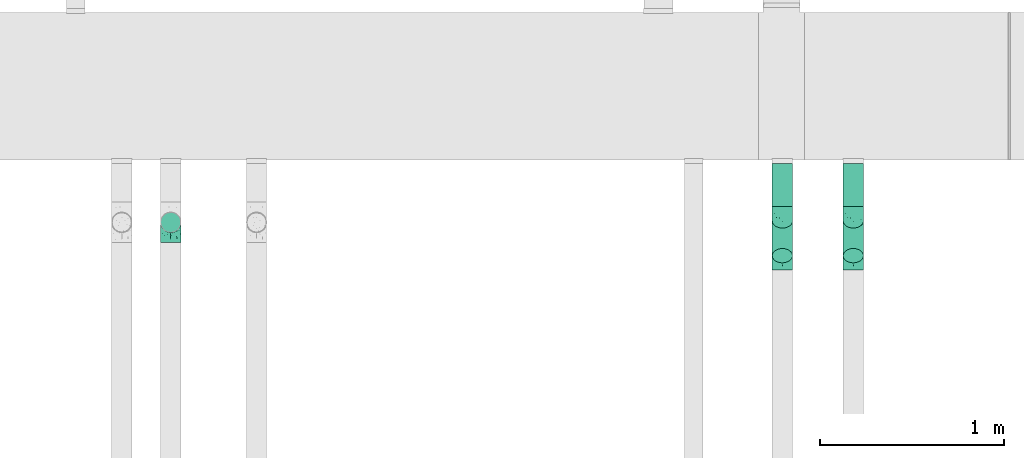
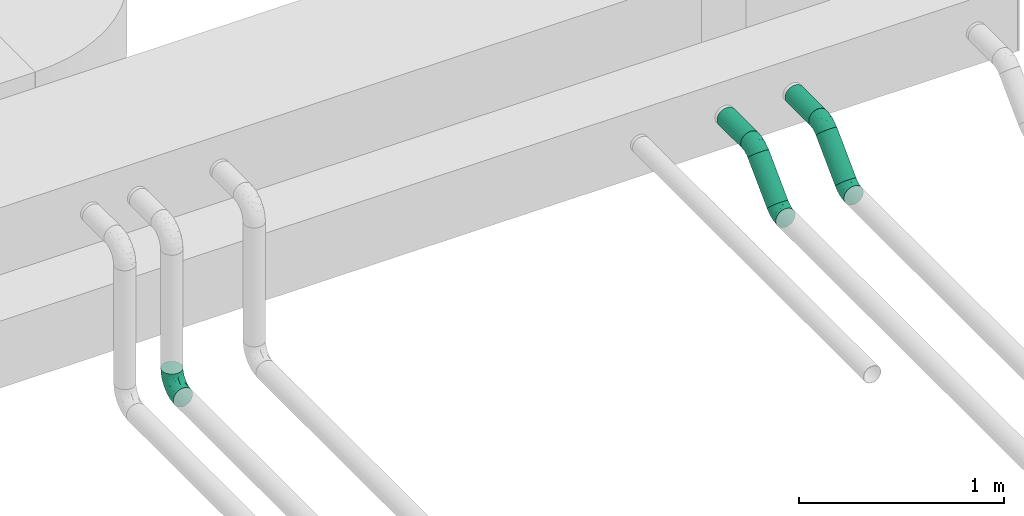
# One storey, part 60 of 91: 5 flow fittings, 4 flow segments.
"""IFC2X3 building model written with IfcOpenShell, lengths in millimetres."""

from ifc_helpers import new_model, entity, si_unit, converted_unit, derived_unit, direction, frame, origin_with_axes, origin_2d_with_axis, place, context, subcontext, project, spatial, hollow_circle, extrude, open_shell, surface_model, source, transform, mapped, material, layer, layer_set, layer_usage, type_object, element, save


model = new_model("IFC2X3")

# Units and contexts
model_context = context("Model", 3, precision=1e-05, world=origin_with_axes(), true_north=direction((0.0, 1.0)))
body_context = subcontext(model_context, "Body", "Model", "MODEL_VIEW")
ifc_project = project(units=[si_unit("AREAUNIT", "SQUARE_METRE"), si_unit("VOLUMEUNIT", "CUBIC_METRE", prefix="DECI"), si_unit("TIMEUNIT", "SECOND"), si_unit("THERMODYNAMICTEMPERATUREUNIT", "DEGREE_CELSIUS"), si_unit("PRESSUREUNIT", "PASCAL"), si_unit("MASSUNIT", "GRAM", prefix="KILO"), si_unit("LENGTHUNIT", "METRE", prefix="MILLI"), si_unit("POWERUNIT", "WATT"), si_unit("ELECTRICCURRENTUNIT", "AMPERE"), si_unit("ELECTRICVOLTAGEUNIT", "VOLT"), derived_unit("VOLUMETRICFLOWRATEUNIT", [(si_unit("VOLUMEUNIT", "CUBIC_METRE", prefix="DECI"), 1), (si_unit("TIMEUNIT", "SECOND"), -1)]), derived_unit("LINEARVELOCITYUNIT", [(si_unit("LENGTHUNIT", "METRE"), 1), (si_unit("TIMEUNIT", "SECOND"), -1)]), derived_unit("MASSDENSITYUNIT", [(si_unit("MASSUNIT", "GRAM", prefix="KILO"), 1), (si_unit("VOLUMEUNIT", "CUBIC_METRE"), -1)]), converted_unit("PLANEANGLEUNIT", "DEGREE", entity("IfcRatioMeasure", 0.01745), si_unit("PLANEANGLEUNIT", "RADIAN"), dimensions=[0, 0, 0, 0, 0, 0, 0])], contexts=[model_context])

# Site, building, storey
site_placement = place(None, origin_with_axes())
site = spatial("IfcSite", under=ifc_project, at=site_placement, CompositionType="ELEMENT")
building_placement = place(site_placement, origin_with_axes())
building = spatial("IfcBuilding", under=site, at=building_placement, Name="mc-building", CompositionType="ELEMENT")
storey_placement = place(building_placement, frame((0.0, 0.0, 8700.0), z_axis=(0.0, 0.0, 1.0), x_axis=(1.0, 0.0, 0.0)))
storey = spatial("IfcBuildingStorey", under=building, at=storey_placement, CompositionType="ELEMENT", Elevation=8700.0)

# Flow fitting
duct_fitting_type = type_object("IfcDuctFittingType", Name="BU", PredefinedType="BEND")
shared_shape_1 = source(origin_with_axes(), body_context, "Body", "SurfaceModel", [
    surface_model("IfcShellBasedSurfaceModel", [(-110.0, 0.0, -55.0), (-110.0, -14.23505, -53.12592), (-110.0, 14.23505, -53.12592), (-110.0, 53.12592, 14.23505), (-110.0, 27.5, -47.63139), (-110.0, 38.89087, -38.89087), (-110.0, -55.0, 0.0), (-110.0, -53.12592, 14.23505), (-110.0, -38.89087, -38.89087), (-110.0, -27.5, -47.63139), (-110.0, -53.12592, -14.23505), (-110.0, -47.63139, -27.5), (-110.0, -14.23505, 53.12592), (-110.0, 14.23505, 53.12592), (-110.0, 27.5, 47.63139), (-110.0, -47.63139, 27.5), (-110.0, -38.89087, 38.89087), (-110.0, -27.5, 47.63139), (-110.0, 0.0, 55.0), (-110.0, 55.0, 0.0), (-110.0, 53.12592, -14.23505), (-110.0, 47.63139, -27.5), (-110.0, 47.63139, 27.5), (-110.0, 38.89087, 38.89087), (-14.23505, 110.0, -53.12592), (-55.0, 110.0, 0.0), (0.0, 110.0, -55.0), (-27.5, 110.0, -47.63139), (-38.89087, 110.0, -38.89087), (-47.63139, 110.0, -27.5), (38.89087, 110.0, -38.89087), (53.12592, 110.0, 14.23505), (27.5, 110.0, -47.63139), (14.23505, 110.0, -53.12592), (47.63139, 110.0, -27.5), (53.12592, 110.0, -14.23505), (55.0, 110.0, 0.0), (-53.12592, 110.0, -14.23505), (-53.12592, 110.0, 14.23505), (-47.63139, 110.0, 27.5), (-38.89087, 110.0, 38.89087), (-27.5, 110.0, 47.63139), (0.0, 110.0, 55.0), (-14.23505, 110.0, 53.12592), (38.89087, 110.0, 38.89087), (47.63139, 110.0, 27.5), (27.5, 110.0, 47.63139), (14.23505, 110.0, 53.12592), (-64.21732, 48.68956, 43.63444), (-76.6405, 38.18013, 45.55988), (-60.44912, 32.56953, 51.94617), (-76.00813, 5.38378, 55.0), (-90.15553, 11.94394, 54.09138), (-78.5998, 26.77405, 50.81338), (-70.18771, 18.55163, 54.03432), (-75.55424, 54.2118, 32.41257), (-93.27622, 45.77614, 33.48188), (-96.12334, 22.13664, 50.81337), (-21.00813, 45.34362, 55.0), (-18.36258, 70.48427, 54.04484), (-32.04182, 59.64019, 52.24446), (-63.88653, 74.77858, 17.99134), (-74.66383, 63.08407, 19.92123), (-63.60674, 66.07878, 29.97482), (-99.597, 52.72185, 18.52927), (-93.11138, 56.59448, 10.50359), (-98.21577, 57.34403, 0.0), (-53.42855, 92.60092, 21.04759), (-88.54852, 54.8376, 21.04759), (-11.86161, 90.23965, 54.10313), (-5.38378, 76.00813, 55.0), (-57.34403, 98.21577, 0.0), (-56.64619, 93.12774, 10.22088), (-45.34362, 21.00813, 55.0), (-44.60838, 44.60838, 52.13415), (-92.68484, 35.46673, 43.63443), (-22.25266, 95.40765, 50.81337), (-35.97783, 90.61597, 43.63443), (-43.70931, 69.58671, 44.47149), (-27.23711, 77.39884, 50.81337), (-57.2828, 79.3123, 24.9774), (-58.67786, 84.31125, 16.04456), (-82.93277, 60.36161, 12.91784), (-49.88337, 54.51816, 47.224), (-74.57753, 66.83759, 9.55742), (-45.35812, 94.97281, 33.48188), (-59.18663, 88.95241, 0.0), (-51.517, 78.6292, 33.48188), (-65.14788, 80.03077, 0.0), (-56.45322, 62.06476, 39.63545), (-88.95241, 59.18663, 0.0), (-71.10913, 71.10913, 0.0), (-80.03077, 65.14788, 0.0), (-94.9309, 45.36788, -33.48188), (-93.11358, 56.60141, -10.46614), (-99.64997, 52.79499, -18.30015), (-90.20425, 36.08686, -43.63443), (-79.99933, 46.56772, -37.92748), (-76.00813, 5.38378, -55.0), (-72.75364, 19.68651, -53.60527), (-45.34362, 21.00813, -55.0), (-21.91957, 65.12078, -53.85897), (-5.38378, 76.00813, -55.0), (-21.00813, 45.34362, -55.0), (-35.41876, 92.89265, -43.63443), (-91.10309, 11.02766, -54.21832), (-45.77614, 93.27622, -33.48188), (-90.50474, 23.21022, -50.81337), (-70.92854, 33.31794, -49.51754), (-78.52933, 63.35627, -11.73997), (-24.91508, 84.05606, -50.81337), (-88.78941, 54.74452, -21.04759), (-69.59921, 57.34866, -33.48187), (-73.36422, 62.46673, -22.94182), (-63.49062, 67.59111, -28.46929), (-56.59448, 93.11138, -10.50359), (-54.8376, 88.54852, -21.04759), (-54.10679, 75.85581, -32.31867), (-57.75956, 31.09612, -52.80882), (-52.72185, 99.597, -18.52927), (-12.62913, 89.46304, -53.99097), (-34.46825, 66.46123, -50.04329), (-43.9837, 43.9837, -52.42279), (-65.78527, 72.58348, -17.68796), (-70.34468, 43.65295, -44.21951), (-57.47001, 51.99467, -44.91465), (-60.72547, 82.29174, -12.88567), (-42.34915, 74.24548, -43.63444), (-57.25194, 63.5016, -38.08211), (-80.95344, 53.56991, -29.32027), (-52.32891, 4.55257, -54.0482), (32.52942, 47.13398, -30.48571), (14.88266, 20.92917, -33.7947), (14.95561, 36.05775, -42.26543), (30.24048, 70.09027, -41.7461), (19.3559, 65.35825, -48.00507), (-70.35075, -46.44478, -19.5952), (-47.13398, -32.52942, -30.48571), (-28.49299, -30.5778, -16.4009), (-4.55257, 52.32891, -54.0482), (-22.4954, 22.4954, -53.25347), (-75.47368, -11.22546, -52.60718), (-81.32209, -51.5606, -9.98467), (-80.81763, -41.84862, -32.14655), (-70.09027, -30.24048, -41.7461), (-36.05774, -14.95561, -42.26543), (-9.15831, -10.852, -27.8997), (-65.35825, -19.3559, -48.00507), (11.22546, 75.47368, -52.60718), (3.94376, 43.9333, -50.53315), (-13.39742, 13.39743, -48.13058), (-43.9333, -3.94376, -50.53315), (49.37776, 67.29486, 0.0), (41.8609, 47.82256, -9.92641), (50.20582, 74.51695, -9.9731), (18.93131, 11.7156, -17.56239), (-27.5, -32.89419, 0.0), (-1.23348, -12.25375, -12.18106), (41.84862, 80.81763, -32.14655), (35.70604, 41.31408, -20.38235), (46.44478, 70.35075, -19.5952), (32.89419, 27.5, 0.0), (6.67262, -6.67262, 0.0), (-67.29486, -49.37776, 0.0), (-50.36265, -42.95545, -9.51562), (-5.47251, 5.47251, -39.92906), (-70.35075, -46.44478, 19.5952), (-74.51695, -50.20582, 9.9731), (-41.31407, -35.70604, 20.38235), (-47.13398, -32.52942, 30.48571), (-80.81763, -41.84862, 32.14655), (-4.55257, 52.32891, 54.0482), (11.22546, 75.47368, 52.60718), (-43.9333, -3.94376, 50.53315), (-65.35825, -19.3559, 48.00507), (-36.05774, -14.95561, 42.26543), (-70.09027, -30.24048, 41.7461), (-11.7156, -18.93131, 17.56239), (30.5778, 28.49299, 16.4009), (12.25375, 1.23348, 12.18106), (51.5606, 81.32209, 9.98467), (42.95545, 50.36265, 9.51562), (-75.47368, -11.22546, 52.60718), (-52.32891, 4.55257, 54.0482), (3.94376, 43.9333, 50.53315), (-22.4954, 22.4954, 53.25347), (-13.39742, 13.39743, 48.13058), (10.852, 9.15831, 27.8997), (-20.92916, -14.88266, 33.79469), (-47.82256, -41.8609, 9.92641), (32.52942, 47.13398, 30.48571), (46.44478, 70.35075, 19.5952), (41.84862, 80.81763, 32.14655), (30.24048, 70.09027, 41.7461), (19.3559, 65.35825, 48.00507), (14.95561, 36.05775, 42.26543), (-5.47251, 5.47251, 39.92906)], [open_shell([[[0, 1, 2]], [[2, 3, 4]], [[4, 3, 5]], [[2, 6, 7]], [[8, 6, 9]], [[1, 9, 6]], [[10, 6, 11]], [[8, 11, 6]], [[6, 2, 1]], [[12, 13, 14]], [[15, 2, 7]], [[16, 17, 2]], [[2, 17, 12]], [[12, 18, 13]], [[19, 20, 3]], [[5, 3, 21]], [[20, 21, 3]], [[22, 3, 2]], [[23, 22, 2]], [[12, 14, 2]], [[2, 14, 23]], [[15, 16, 2]], [[24, 25, 26]], [[27, 25, 24]], [[25, 28, 29]], [[28, 25, 27]], [[30, 26, 31]], [[26, 30, 32]], [[32, 33, 26]], [[34, 31, 35]], [[31, 34, 30]], [[35, 31, 36]], [[29, 37, 25]], [[38, 39, 26]], [[39, 40, 26]], [[41, 42, 40]], [[42, 26, 40]], [[42, 41, 43]], [[26, 44, 45]], [[31, 26, 45]], [[26, 46, 44]], [[47, 46, 26]], [[42, 47, 26]], [[25, 38, 26]], [[48, 49, 50]], [[18, 51, 52]], [[53, 54, 50]], [[55, 56, 49]], [[56, 22, 23]], [[13, 57, 14]], [[58, 59, 60]], [[61, 62, 63]], [[3, 64, 65]], [[53, 52, 54]], [[3, 65, 66]], [[67, 39, 38]], [[56, 68, 64]], [[65, 64, 68]], [[69, 59, 70]], [[38, 71, 72]], [[73, 58, 74]], [[75, 49, 56]], [[76, 69, 43]], [[53, 57, 52]], [[77, 78, 79]], [[41, 76, 43]], [[43, 69, 42]], [[55, 68, 56]], [[23, 14, 75]], [[76, 77, 79]], [[80, 67, 81]], [[62, 82, 68]], [[60, 78, 83]], [[62, 84, 82]], [[85, 77, 40]], [[81, 67, 72]], [[86, 72, 71]], [[87, 85, 67]], [[61, 81, 88]], [[77, 41, 40]], [[78, 77, 87]], [[23, 75, 56]], [[83, 89, 48]], [[85, 40, 39]], [[62, 68, 55]], [[89, 87, 63]], [[83, 48, 50]], [[57, 75, 14]], [[49, 75, 53]], [[67, 85, 39]], [[87, 77, 85]], [[63, 62, 55]], [[89, 55, 48]], [[80, 63, 87]], [[66, 65, 90]], [[66, 19, 3]], [[84, 91, 92]], [[92, 90, 82]], [[65, 82, 90]], [[61, 84, 62]], [[92, 82, 84]], [[68, 82, 65]], [[3, 22, 64]], [[56, 64, 22]], [[38, 25, 71]], [[81, 72, 86]], [[38, 72, 67]], [[91, 61, 88]], [[80, 81, 61]], [[63, 80, 61]], [[67, 80, 87]], [[77, 76, 41]], [[79, 59, 69]], [[79, 69, 76]], [[42, 69, 70]], [[60, 59, 79]], [[58, 70, 59]], [[78, 60, 79]], [[58, 60, 74]], [[52, 57, 13]], [[75, 57, 53]], [[18, 52, 13]], [[52, 51, 54]], [[51, 73, 54]], [[50, 73, 74]], [[73, 50, 54]], [[50, 74, 83]], [[60, 83, 74]], [[89, 83, 78]], [[87, 89, 78]], [[55, 89, 63]], [[50, 49, 53]], [[55, 49, 48]], [[81, 86, 88]], [[91, 84, 61]], [[5, 21, 93]], [[90, 94, 66]], [[20, 94, 95]], [[96, 93, 97]], [[98, 99, 100]], [[96, 4, 5]], [[101, 102, 103]], [[28, 27, 104]], [[2, 105, 0]], [[104, 106, 28]], [[99, 105, 107]], [[108, 107, 96]], [[90, 109, 94]], [[107, 2, 4]], [[20, 66, 94]], [[27, 24, 110]], [[109, 111, 94]], [[112, 113, 114]], [[37, 115, 71]], [[116, 106, 117]], [[99, 118, 100]], [[116, 115, 119]], [[37, 119, 115]], [[24, 120, 110]], [[121, 110, 101]], [[119, 106, 116]], [[101, 110, 120]], [[122, 103, 100]], [[117, 123, 116]], [[124, 125, 108]], [[115, 116, 126]], [[106, 29, 28]], [[26, 102, 120]], [[127, 104, 110]], [[97, 124, 96]], [[125, 122, 118]], [[128, 127, 125]], [[96, 5, 93]], [[115, 126, 86]], [[117, 106, 127]], [[111, 113, 129]], [[95, 93, 21]], [[97, 129, 112]], [[110, 104, 27]], [[106, 104, 127]], [[96, 107, 4]], [[99, 107, 108]], [[99, 108, 118]], [[105, 99, 98]], [[112, 114, 128]], [[121, 125, 127]], [[20, 19, 66]], [[109, 90, 92]], [[94, 111, 95]], [[91, 123, 109]], [[129, 113, 112]], [[93, 95, 111]], [[21, 20, 95]], [[71, 115, 86]], [[71, 25, 37]], [[123, 91, 88]], [[126, 116, 123]], [[123, 88, 126]], [[86, 126, 88]], [[37, 29, 119]], [[106, 119, 29]], [[129, 93, 111]], [[124, 112, 125]], [[0, 105, 98]], [[107, 105, 2]], [[125, 118, 108]], [[100, 118, 122]], [[93, 129, 97]], [[113, 111, 109]], [[109, 123, 113]], [[114, 123, 117]], [[123, 114, 113]], [[128, 114, 117]], [[127, 128, 117]], [[112, 128, 125]], [[103, 122, 101]], [[110, 121, 127]], [[101, 122, 121]], [[125, 121, 122]], [[26, 120, 24]], [[101, 120, 102]], [[96, 124, 108]], [[92, 91, 109]], [[112, 124, 97]], [[100, 130, 98]], [[131, 132, 133]], [[32, 134, 135]], [[136, 137, 138]], [[139, 140, 103]], [[98, 141, 0]], [[142, 10, 136]], [[143, 144, 137]], [[6, 10, 142]], [[137, 145, 146]], [[144, 147, 145]], [[143, 136, 11]], [[11, 136, 10]], [[8, 143, 11]], [[148, 149, 139]], [[8, 9, 144]], [[9, 1, 147]], [[130, 141, 98]], [[103, 140, 100]], [[148, 135, 149]], [[150, 151, 140]], [[152, 153, 154]], [[130, 140, 151]], [[148, 26, 33]], [[147, 1, 141]], [[155, 146, 132]], [[156, 138, 157]], [[134, 30, 158]], [[150, 140, 149]], [[158, 30, 34]], [[30, 134, 32]], [[153, 159, 160]], [[131, 160, 159]], [[144, 145, 137]], [[36, 152, 154]], [[146, 138, 137]], [[155, 161, 162]], [[158, 160, 131]], [[133, 149, 135]], [[156, 163, 164]], [[163, 142, 164]], [[139, 103, 102]], [[153, 152, 161]], [[34, 35, 160]], [[162, 157, 155]], [[132, 165, 133]], [[157, 146, 155]], [[140, 130, 100]], [[141, 130, 151]], [[141, 151, 147]], [[141, 1, 0]], [[102, 26, 148]], [[140, 139, 149]], [[102, 148, 139]], [[135, 33, 32]], [[151, 150, 145]], [[9, 147, 144]], [[151, 145, 147]], [[145, 165, 146]], [[135, 148, 33]], [[133, 135, 134]], [[131, 133, 134]], [[133, 165, 150]], [[133, 150, 149]], [[145, 150, 165]], [[132, 131, 159]], [[146, 165, 132]], [[160, 158, 34]], [[134, 158, 131]], [[144, 143, 8]], [[136, 143, 137]], [[155, 153, 161]], [[154, 153, 160]], [[153, 155, 159]], [[132, 159, 155]], [[160, 35, 154]], [[36, 154, 35]], [[164, 136, 138]], [[6, 142, 163]], [[136, 164, 142]], [[156, 164, 138]], [[156, 157, 162]], [[146, 157, 138]], [[15, 7, 166]], [[6, 163, 167]], [[168, 169, 166]], [[166, 169, 170]], [[171, 172, 70]], [[173, 174, 175]], [[17, 176, 174]], [[177, 156, 162]], [[176, 16, 170]], [[170, 16, 15]], [[161, 178, 179]], [[152, 180, 181]], [[182, 173, 183]], [[18, 12, 182]], [[184, 185, 186]], [[183, 185, 73]], [[183, 73, 51]], [[177, 187, 188]], [[189, 168, 166]], [[187, 178, 190]], [[16, 176, 17]], [[161, 152, 181]], [[45, 191, 31]], [[45, 44, 192]], [[192, 191, 45]], [[180, 36, 31]], [[193, 194, 195]], [[46, 47, 194]], [[193, 195, 190]], [[193, 44, 46]], [[172, 42, 70]], [[185, 58, 73]], [[189, 163, 156]], [[163, 189, 167]], [[70, 58, 171]], [[184, 171, 185]], [[169, 188, 175]], [[180, 31, 191]], [[192, 193, 190]], [[191, 190, 178]], [[182, 174, 173]], [[194, 47, 172]], [[190, 195, 187]], [[186, 185, 173]], [[162, 179, 177]], [[188, 196, 175]], [[179, 187, 177]], [[185, 171, 58]], [[172, 171, 184]], [[172, 184, 194]], [[172, 47, 42]], [[51, 18, 182]], [[185, 183, 173]], [[51, 182, 183]], [[174, 12, 17]], [[184, 186, 195]], [[46, 194, 193]], [[184, 195, 194]], [[195, 196, 187]], [[174, 182, 12]], [[175, 174, 176]], [[169, 175, 176]], [[175, 196, 186]], [[175, 186, 173]], [[195, 186, 196]], [[188, 169, 168]], [[187, 196, 188]], [[166, 170, 15]], [[176, 170, 169]], [[193, 192, 44]], [[191, 192, 190]], [[177, 189, 156]], [[167, 189, 166]], [[189, 177, 168]], [[188, 168, 177]], [[166, 7, 167]], [[6, 167, 7]], [[181, 191, 178]], [[36, 180, 152]], [[191, 181, 180]], [[161, 181, 178]], [[161, 179, 162]], [[187, 179, 178]]])]),
])
flow_fitting_placement = place(storey_placement, frame((30053.28275, 2612.35324, 415.0), z_axis=(1.0, 0.0, 0.0), x_axis=(0.0, 1.0, 0.0)))
element("IfcFlowFitting", 1, at=flow_fitting_placement, inside=storey, type_object=duct_fitting_type, Name="BU", context=body_context, shape_type="MappedRepresentation", body=[
    mapped(shared_shape_1, transform((0.0, 0.0, 0.0), scale=1.0)),
])

# Flow segments
ifc_material = material(Name="FZ1")
ifc_layer = layer(ifc_material, 0.0)
ifc_layer_set = layer_set([ifc_layer], Name="FZ1")
ifc_layer_usage = layer_usage(ifc_layer_set, "AXIS1", "POSITIVE", 0.0)
duct_segment_type = type_object("IfcDuctSegmentType", PredefinedType="RIGIDSEGMENT")
shared_shape_2 = source(origin_with_axes(), body_context, "Body", "SweptSolid", [
    extrude(hollow_circle(Radius=55.0, WallThickness=2.0, at=origin_2d_with_axis()), frame((0.0, 0.0, 0.0), z_axis=(1.0, 0.0, 0.0), x_axis=(0.0, 1.0, 0.0)), (0.0, 0.0, 1.0), 266.7),
])
for number, where, z_axis, x_axis in (
    (2, (33368.54901, 2620.42338, 635.78175), (0.0, -0.707107, 0.707107), (0.0, -0.707107, -0.707107)),
    (3, (33752.94253, 2620.42338, 635.78175), (0.0, -0.707107, 0.707107), (0.0, -0.707107, -0.707107)),
):
    element("IfcFlowSegment", number, at=place(storey_placement, frame(where, z_axis=z_axis, x_axis=x_axis)), inside=storey, type_object=duct_segment_type, material=ifc_layer_usage, context=body_context, shape_type="MappedRepresentation", body=[
        mapped(shared_shape_2, transform((0.0, 0.0, 0.0), scale=1.0)),
    ])

# Flow fittings
shared_shape_3 = source(origin_with_axes(), body_context, "Body", "SurfaceModel", [
    surface_model("IfcShellBasedSurfaceModel", [(-45.56349, 0.0, -55.0), (-45.56349, -14.23505, -53.12592), (-45.56349, 14.23505, -53.12592), (-45.56349, 53.12592, 14.23505), (-45.56349, 27.5, -47.63139), (-45.56349, 38.89087, -38.89087), (-45.56349, 47.63139, -27.5), (-45.56349, -55.0, 0.0), (-45.56349, -53.12592, 14.23505), (-45.56349, -38.89087, -38.89087), (-45.56349, -27.5, -47.63139), (-45.56349, -53.12592, -14.23505), (-45.56349, -47.63139, -27.5), (-45.56349, 53.12592, -14.23505), (-45.56349, 47.63139, 27.5), (-45.56349, 38.89087, 38.89087), (-45.56349, -14.23505, 53.12592), (-45.56349, 27.5, 47.63139), (-45.56349, 14.23505, 53.12592), (-45.56349, -47.63139, 27.5), (-45.56349, -38.89087, 38.89087), (-45.56349, -27.5, 47.63139), (-45.56349, 0.0, 55.0), (-45.56349, 55.0, 0.0), (22.15256, 42.28395, -53.12592), (-6.67262, 71.10913, 0.0), (32.21826, 32.21826, -55.0), (12.77282, 51.66369, -47.63139), (-1.46223, 65.89874, -27.5), (4.71825, 59.71825, -38.89087), (59.71825, 4.71825, -38.89087), (69.78395, -5.34744, 14.23505), (51.66369, 12.77282, -47.63139), (42.28395, 22.15256, -53.12592), (65.89874, -1.46223, -27.5), (69.78395, -5.34744, -14.23505), (71.10913, -6.67262, 0.0), (-5.34744, 69.78395, -14.23505), (-5.34744, 69.78395, 14.23505), (-1.46223, 65.89874, 27.5), (4.71825, 59.71825, 38.89087), (32.21826, 32.21826, 55.0), (12.77282, 51.66369, 47.63139), (22.15256, 42.28395, 53.12592), (59.71825, 4.71825, 38.89087), (65.89874, -1.46223, 27.5), (42.28395, 22.15256, 53.12592), (51.66369, 12.77282, 47.63139), (-20.16649, 48.68621, 33.48188), (-26.97111, 35.77503, 43.63444), (-7.30443, 43.73336, 43.63444), (-17.0934, 3.74816, 55.0), (-18.00408, 15.44793, 53.78143), (-30.11707, 22.39897, 50.81337), (-7.49776, 55.63651, 33.48188), (-15.97018, 58.74288, 21.04759), (-31.18231, 52.58712, 21.04759), (-18.35174, 61.03934, 10.51509), (-28.67677, 56.60048, 10.47121), (-34.03924, 44.64267, 33.48188), (-11.52288, 27.81868, 50.81338), (1.19951, 23.16465, 53.81115), (-33.77926, 57.34403, 0.0), (5.4586, 37.12132, 50.81809), (-24.5159, 59.18663, 0.0), (-16.66281, 64.4339, 0.0), (9.43651, 14.73721, 55.0), (-6.22531, 44.36822, -43.63444), (5.4586, 37.12132, -50.81809), (-34.03924, 44.64267, -33.48188), (9.43651, 14.73721, -55.0), (-17.0934, 3.74816, -55.0), (1.19951, 23.16465, -53.81115), (-11.52288, 27.81868, -50.81338), (-30.11707, 22.39897, -50.81337), (-25.75914, 36.08917, -43.63444), (-30.24487, 52.83011, -21.04759), (-20.16649, 48.68621, -33.48188), (-7.49776, 55.63651, -33.48188), (-18.00408, 15.44793, -53.78143), (-28.68366, 56.62226, -10.35271), (-14.15883, 63.53074, -10.87592), (-15.13548, 59.23394, -21.04759), (3.19797, -7.72059, -52.16847), (3.1272, -18.04126, -47.9241), (13.63233, -32.91136, -32.06475), (45.23618, -22.99734, -20.4997), (16.67434, -40.25541, -15.9539), (-17.3935, -51.68264, -9.80849), (-2.85835, -49.37776, 0.0), (48.84421, -24.24609, -9.80849), (-16.38424, -42.76862, -30.85433), (-6.97383, -29.41689, -42.70541), (41.82739, -18.65658, -30.85433), (-15.72523, -48.24839, -20.4997), (29.28945, -13.63928, -42.80781), (26.81493, -3.56603, -49.15704), (36.93651, -32.89419, 0.0), (-15.72523, -48.24839, 20.4997), (-17.3935, -51.68264, 9.80849), (-16.38424, -42.76862, 30.85433), (16.67434, -40.25541, 15.9539), (3.19797, -7.72059, 52.16847), (10.54583, -14.96836, 47.9241), (13.63233, -32.91136, 32.06475), (45.23618, -22.99734, 20.4997), (41.82739, -18.65658, 30.85433), (-11.06635, -30.3552, 42.80781), (25.73213, -15.86964, 42.70541), (-16.43945, -21.48258, 49.15704), (48.84421, -24.24609, 9.80849)], [open_shell([[[0, 1, 2]], [[2, 3, 4]], [[5, 3, 6]], [[4, 3, 5]], [[2, 7, 8]], [[9, 7, 10]], [[1, 10, 7]], [[11, 7, 12]], [[9, 12, 7]], [[7, 2, 1]], [[13, 6, 3]], [[14, 3, 2]], [[15, 14, 2]], [[16, 17, 2]], [[2, 17, 15]], [[16, 18, 17]], [[19, 20, 2]], [[19, 2, 8]], [[20, 21, 2]], [[2, 21, 16]], [[16, 22, 18]], [[23, 13, 3]], [[24, 25, 26]], [[27, 25, 24]], [[28, 25, 29]], [[29, 25, 27]], [[30, 26, 31]], [[26, 30, 32]], [[32, 33, 26]], [[34, 31, 35]], [[31, 34, 30]], [[35, 31, 36]], [[37, 25, 28]], [[26, 38, 39]], [[26, 39, 40]], [[41, 40, 42]], [[26, 40, 41]], [[42, 43, 41]], [[26, 44, 45]], [[31, 26, 45]], [[46, 47, 26]], [[47, 44, 26]], [[46, 26, 41]], [[26, 25, 38]], [[48, 49, 50]], [[22, 51, 52]], [[17, 49, 15]], [[53, 17, 18]], [[49, 17, 53]], [[54, 50, 40]], [[48, 55, 56]], [[55, 57, 58]], [[59, 14, 15]], [[60, 53, 52]], [[50, 49, 60]], [[58, 3, 56]], [[52, 51, 61]], [[62, 23, 3]], [[63, 50, 60]], [[50, 42, 40]], [[3, 58, 62]], [[43, 61, 41]], [[62, 58, 64]], [[48, 59, 49]], [[14, 56, 3]], [[40, 39, 54]], [[57, 64, 58]], [[39, 38, 55]], [[63, 60, 61]], [[54, 55, 48]], [[65, 57, 38]], [[56, 14, 59]], [[38, 25, 65]], [[60, 52, 61]], [[49, 59, 15]], [[55, 58, 56]], [[56, 59, 48]], [[55, 54, 39]], [[50, 54, 48]], [[18, 22, 52]], [[49, 53, 60]], [[18, 52, 53]], [[61, 51, 66]], [[41, 61, 66]], [[63, 61, 43]], [[43, 42, 63]], [[50, 63, 42]], [[38, 57, 55]], [[64, 57, 65]], [[67, 27, 68]], [[69, 5, 6]], [[70, 71, 72]], [[73, 74, 75]], [[76, 77, 69]], [[29, 78, 28]], [[2, 79, 0]], [[13, 23, 62]], [[2, 74, 79]], [[5, 75, 4]], [[77, 78, 67]], [[13, 62, 80]], [[64, 80, 62]], [[81, 80, 64]], [[67, 73, 75]], [[82, 77, 76]], [[81, 64, 65]], [[76, 69, 6]], [[82, 76, 80]], [[24, 72, 68]], [[74, 2, 4]], [[27, 67, 29]], [[26, 70, 72]], [[69, 75, 5]], [[82, 28, 78]], [[72, 71, 79]], [[6, 13, 76]], [[77, 67, 75]], [[13, 80, 76]], [[82, 37, 28]], [[81, 25, 37]], [[82, 81, 37]], [[75, 69, 77]], [[67, 78, 29]], [[82, 78, 77]], [[75, 74, 4]], [[79, 74, 73]], [[79, 73, 72]], [[79, 71, 0]], [[68, 72, 73]], [[26, 72, 24]], [[67, 68, 73]], [[27, 24, 68]], [[80, 81, 82]], [[25, 81, 65]], [[1, 83, 84]], [[85, 86, 87]], [[0, 71, 1]], [[88, 87, 89]], [[90, 86, 35]], [[91, 92, 85]], [[11, 88, 7]], [[30, 34, 93]], [[11, 12, 94]], [[92, 91, 9]], [[85, 94, 91]], [[94, 85, 87]], [[95, 93, 85]], [[85, 92, 95]], [[83, 71, 70]], [[12, 9, 91]], [[70, 26, 33]], [[96, 84, 83]], [[1, 71, 83]], [[95, 96, 32]], [[95, 30, 93]], [[95, 32, 30]], [[97, 89, 87]], [[34, 86, 93]], [[36, 97, 90]], [[94, 88, 11]], [[34, 35, 86]], [[90, 87, 86]], [[93, 86, 85]], [[32, 96, 33]], [[84, 10, 1]], [[33, 83, 70]], [[94, 12, 91]], [[10, 92, 9]], [[87, 88, 94]], [[7, 88, 89]], [[36, 90, 35]], [[87, 90, 97]], [[84, 95, 92]], [[33, 96, 83]], [[95, 84, 96]], [[10, 84, 92]], [[8, 98, 19]], [[7, 89, 99]], [[19, 98, 100]], [[101, 98, 99]], [[46, 102, 103]], [[104, 105, 106]], [[100, 98, 104]], [[107, 104, 108]], [[16, 51, 22]], [[51, 16, 102]], [[107, 20, 100]], [[107, 109, 21]], [[21, 20, 107]], [[103, 47, 46]], [[101, 89, 97]], [[105, 110, 31]], [[44, 47, 108]], [[105, 104, 101]], [[107, 100, 104]], [[31, 110, 36]], [[109, 16, 21]], [[108, 106, 44]], [[105, 45, 106]], [[41, 66, 46]], [[102, 66, 51]], [[46, 66, 102]], [[104, 98, 101]], [[99, 98, 8]], [[106, 108, 104]], [[110, 101, 97]], [[45, 44, 106]], [[105, 31, 45]], [[20, 19, 100]], [[109, 103, 102]], [[101, 110, 105]], [[36, 110, 97]], [[7, 99, 8]], [[101, 99, 89]], [[103, 107, 108]], [[16, 109, 102]], [[107, 103, 109]], [[47, 103, 108]]])]),
])
for number, where, z_axis, x_axis, name in (
    (4, (33368.54901, 2652.64164, 668.0), (-1.0, 0.0, 0.0), (0.0, 0.707107, 0.707107), "BU"),
    (5, (33368.54901, 2399.64164, 415.0), (1.0, 0.0, 0.0), (0.0, 1.0, 0.0), "BU"),
    (6, (33752.94253, 2652.64164, 668.0), (-1.0, 0.0, 0.0), (0.0, 0.707107, 0.707107), "BU"),
    (7, (33752.94253, 2399.64164, 415.0), (1.0, 0.0, 0.0), (0.0, 1.0, 0.0), "BU"),
):
    element("IfcFlowFitting", number, at=place(storey_placement, frame(where, z_axis=z_axis, x_axis=x_axis)), inside=storey, type_object=duct_fitting_type, Name=name, context=body_context, shape_type="MappedRepresentation", body=[
        mapped(shared_shape_3, transform((0.0, 0.0, 0.0), scale=1.0)),
    ])

# Flow segments
shared_shape_4 = source(origin_with_axes(), body_context, "Body", "SweptSolid", [
    extrude(hollow_circle(Radius=55.0, WallThickness=2.0, at=origin_2d_with_axis()), frame((0.0, 0.0, 0.0), z_axis=(1.0, 0.0, 0.0), x_axis=(0.0, 1.0, 0.0)), (0.0, 0.0, 1.0), 233.0),
])
for number, where, z_axis, x_axis in (
    (8, (33368.54901, 2931.20513, 668.0), (0.0, 0.0, 1.0), (0.0, -1.0, 0.0)),
    (9, (33752.94253, 2931.20513, 668.0), (0.0, 0.0, 1.0), (0.0, -1.0, 0.0)),
):
    element("IfcFlowSegment", number, at=place(storey_placement, frame(where, z_axis=z_axis, x_axis=x_axis)), inside=storey, type_object=duct_segment_type, material=ifc_layer_usage, context=body_context, shape_type="MappedRepresentation", body=[
        mapped(shared_shape_4, transform((0.0, 0.0, 0.0), scale=1.0)),
    ])

save(model, "model.ifc")
